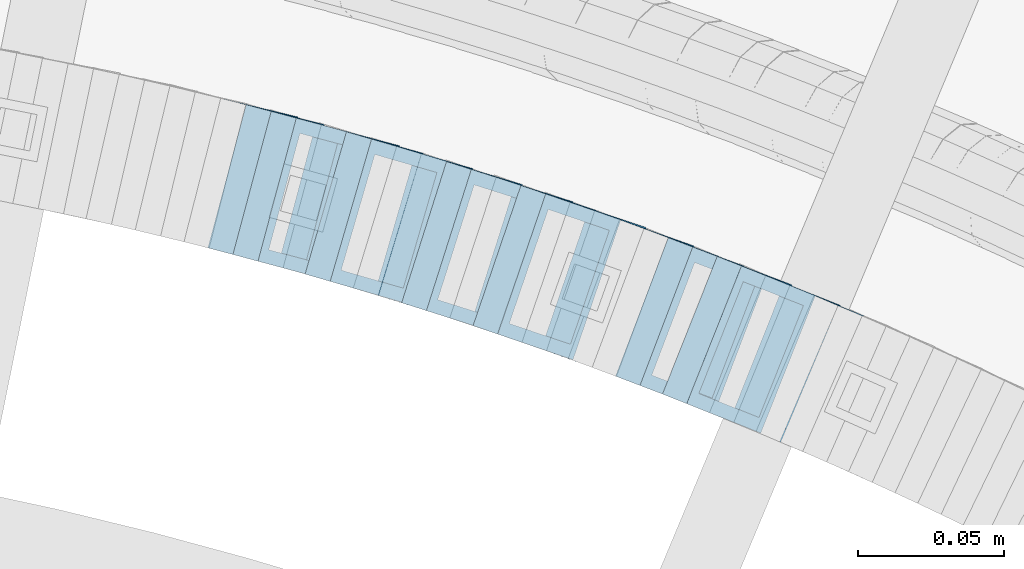
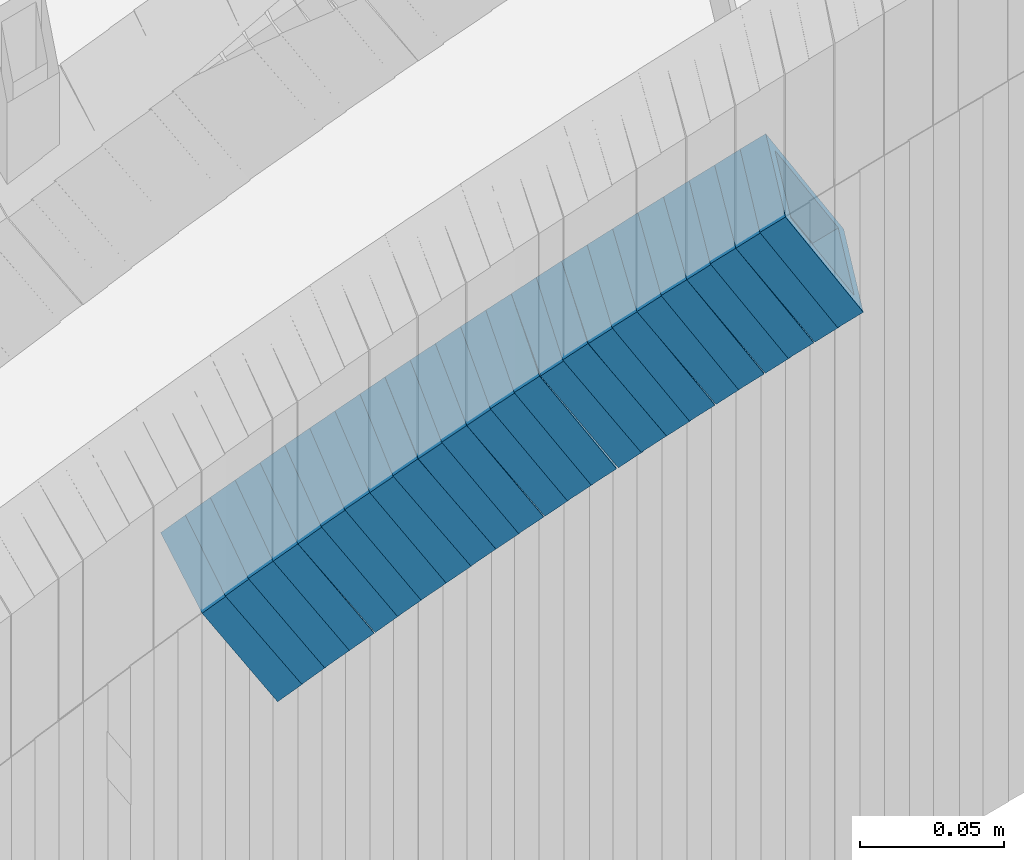
# One storey, part 753 of 975: 24 members.
"""IFC2X3 building model written with IfcOpenShell, lengths in millimetres."""

from ifc_helpers import new_model, si_unit, frame, origin_with_axes, place, context, subcontext, project, spatial, faceted_brep, material, type_object, element, save


model = new_model("IFC2X3")

# Units and contexts
model_context = context("Model", 3, precision=1e-05, world=origin_with_axes())
body_context = subcontext(model_context, "Body", "Model", "MODEL_VIEW")
ifc_project = project(units=[si_unit("LENGTHUNIT", "METRE", prefix="MILLI"), si_unit("AREAUNIT", "SQUARE_METRE"), si_unit("VOLUMEUNIT", "CUBIC_METRE"), si_unit("MASSUNIT", "GRAM", prefix="KILO"), si_unit("TIMEUNIT", "SECOND"), si_unit("PLANEANGLEUNIT", "RADIAN"), si_unit("SOLIDANGLEUNIT", "STERADIAN"), si_unit("THERMODYNAMICTEMPERATUREUNIT", "DEGREE_CELSIUS"), si_unit("LUMINOUSINTENSITYUNIT", "LUMEN")], contexts=[model_context])

# Site, building, storey
site_placement = place(None, origin_with_axes())
site = spatial("IfcSite", under=ifc_project, at=site_placement, CompositionType="ELEMENT")
building_placement = place(site_placement, origin_with_axes())
building = spatial("IfcBuilding", under=site, at=building_placement, Name="Undefined", CompositionType="ELEMENT")
storey_placement = place(building_placement, origin_with_axes())
storey = spatial("IfcBuildingStorey", under=building, at=storey_placement, Name="Undefined", CompositionType="ELEMENT", Elevation=0.0)

# Members
ifc_material = material()
member_type = type_object("IfcMemberType", Name="HSS2X2X.188_TUBES", PredefinedType="NOTDEFINED")
member_1_placement = place(storey_placement, frame((35253.2884853602, 4700.80640177664, 1383.78841235518), z_axis=(0.369459573118605, 0.929246804584777, -8.4115526988171e-11), x_axis=(0.783332654127522, -0.311445513050796, 0.537951341087703)))
element("IfcMember", 1, at=member_1_placement, inside=storey, type_object=member_type, material=ifc_material, Name="WALL", ObjectType="HSS2X2X.188_TUBES", context=body_context, shape_type="Brep", body=[
    faceted_brep([(0.0, 20.6374999999753, -20.6375000000298), (0.0, -20.6375000000153, -20.6375000000153), (10.6004716875832, -20.6375000000153, -20.6375000000553), (10.6004716875814, 20.6374999999898, -20.6375000000444), (0.0, -20.6374999999825, 20.6375000000335), (10.6004716876068, -20.6375000000044, 20.6374999999862), (0.0, 20.6375000000116, 20.6375000000189), (10.6004716876032, 20.6374999999989, 20.6374999999971), (0.0, 25.3999999999724, -25.4000000000342), (0.0, 25.400000000016, 25.4000000000196), (10.600471687605, 25.4000000000015, 25.4000000000051), (10.6004716875814, 25.3999999999869, -25.4000000000487), (0.0, -25.399999999976, 25.4000000000378), (10.6004716876068, -25.4000000000015, 25.3999999999905), (0.0, -25.400000000016, -25.4000000000196), (10.6004716875814, -25.4000000000178, -25.4000000000669)], [[[0, 1, 2, 3]], [[1, 4, 5, 2]], [[4, 6, 7, 5]], [[6, 0, 3, 7]], [[8, 9, 10, 11]], [[9, 12, 13, 10]], [[12, 14, 15, 13]], [[14, 8, 11, 15]], [[13, 15, 11, 10], [5, 7, 3, 2]], [[14, 12, 9, 8], [6, 4, 1, 0]]]),
])
member_2_placement = place(storey_placement, frame((35269.5539152076, 4694.18900324378, 1395.26256360758), z_axis=(0.379066925316801, 0.925369259339679, -5.31522346136625e-11), x_axis=(0.781005694706522, -0.319930043879788, 0.536353308798463)))
element("IfcMember", 2, at=member_2_placement, inside=storey, type_object=member_type, material=ifc_material, Name="WALL", ObjectType="HSS2X2X.188_TUBES", context=body_context, shape_type="Brep", body=[
    faceted_brep([(0.0, 20.6374999999753, -20.6375000000298), (0.0, -20.6375000000153, -20.6375000000153), (10.6348483769107, -20.637499999988, -20.6374999999825), (10.6348483768415, 20.6374999999734, -20.6375000001026), (0.0, -20.6374999999825, 20.6375000000335), (10.6348483769852, -20.6374999999589, 20.6375000001462), (0.0, 20.6375000000116, 20.6375000000189), (10.6348483769161, 20.6375000000044, 20.6375000000226), (0.0, 25.3999999999724, -25.4000000000342), (0.0, 25.400000000016, 25.4000000000196), (10.6348483769179, 25.4000000000015, 25.4000000000233), (10.6348483768288, 25.3999999999669, -25.4000000001324), (0.0, -25.399999999976, 25.4000000000378), (10.6348483769998, -25.3999999999505, 25.4000000001688), (0.0, -25.400000000016, -25.4000000000196), (10.6348483769107, -25.3999999999887, -25.3999999999833)], [[[0, 1, 2, 3]], [[1, 4, 5, 2]], [[4, 6, 7, 5]], [[6, 0, 3, 7]], [[8, 9, 10, 11]], [[9, 12, 13, 10]], [[12, 14, 15, 13]], [[14, 8, 11, 15]], [[13, 15, 11, 10], [5, 7, 3, 2]], [[14, 12, 9, 8], [6, 4, 1, 0]]]),
])
member_3_placement = place(storey_placement, frame((35261.7455766165, 4697.44394380727, 1389.59723822413), z_axis=(0.369459573118605, 0.929246804584777, -8.4115526988171e-11), x_axis=(0.779351312004385, -0.309862570001833, 0.544606941003237)))
element("IfcMember", 3, at=member_3_placement, inside=storey, type_object=member_type, material=ifc_material, Name="WALL", ObjectType="HSS2X2X.188_TUBES", context=body_context, shape_type="Brep", body=[
    faceted_brep([(0.0, 20.6374999999753, -20.6375000000298), (0.0, -20.6375000000153, -20.6375000000153), (10.648004507897, -20.6374999999862, -20.637499999968), (10.6480045078188, 20.6374999999771, -20.6375000000808), (0.0, -20.6374999999825, 20.6375000000335), (10.6480045079406, -20.6374999999698, 20.6375000001062), (0.0, 20.6375000000116, 20.6375000000189), (10.6480045078679, 20.6374999999935, 20.6375000000007), (0.0, 25.3999999999724, -25.4000000000342), (0.0, 25.400000000016, 25.4000000000196), (10.6480045078661, 25.3999999999905, 25.4000000000015), (10.648004507806, 25.3999999999705, -25.4000000000997), (0.0, -25.399999999976, 25.4000000000378), (10.6480045079552, -25.3999999999633, 25.4000000001288), (0.0, -25.400000000016, -25.4000000000196), (10.6480045078988, -25.3999999999814, -25.3999999999651)], [[[0, 1, 2, 3]], [[1, 4, 5, 2]], [[4, 6, 7, 5]], [[6, 0, 3, 7]], [[8, 9, 10, 11]], [[9, 12, 13, 10]], [[12, 14, 15, 13]], [[14, 8, 11, 15]], [[13, 15, 11, 10], [5, 7, 3, 2]], [[14, 12, 9, 8], [6, 4, 1, 0]]]),
])
member_4_placement = place(storey_placement, frame((35236.8444774971, 4707.27920437991, 1372.24919434095), z_axis=(0.355995327441539, 0.934487734986282, -3.27830093738158e-10), x_axis=(0.789193496498296, -0.300645141189797, 0.535524158338129)))
element("IfcMember", 4, at=member_4_placement, inside=storey, type_object=member_type, material=ifc_material, Name="WALL", ObjectType="HSS2X2X.188_TUBES", context=body_context, shape_type="Brep", body=[
    faceted_brep([(0.0, 20.6374999999753, -20.6375000000298), (0.0, -20.6375000000153, -20.6375000000153), (10.6395488625676, -20.6374999999771, -20.6374999999716), (10.6395488625531, 20.6374999999916, -20.6375000000189), (0.0, -20.6374999999825, 20.6375000000335), (10.6395488625731, -20.6374999999844, 20.6375000000153), (0.0, 20.6375000000116, 20.6375000000189), (10.6395488625585, 20.6374999999825, 20.637499999968), (0.0, 25.3999999999724, -25.4000000000342), (0.0, 25.400000000016, 25.4000000000196), (10.6395488625567, 25.3999999999778, 25.3999999999614), (10.6395488625494, 25.3999999999887, -25.4000000000233), (0.0, -25.399999999976, 25.4000000000378), (10.6395488625749, -25.3999999999851, 25.400000000016), (0.0, -25.400000000016, -25.4000000000196), (10.6395488625658, -25.399999999976, -25.3999999999687)], [[[0, 1, 2, 3]], [[1, 4, 5, 2]], [[4, 6, 7, 5]], [[6, 0, 3, 7]], [[8, 9, 10, 11]], [[9, 12, 13, 10]], [[12, 14, 15, 13]], [[14, 8, 11, 15]], [[13, 15, 11, 10], [5, 7, 3, 2]], [[14, 12, 9, 8], [6, 4, 1, 0]]]),
])
member_5_placement = place(storey_placement, frame((35245.4023293793, 4704.01907032952, 1378.05724534033), z_axis=(0.355995327441539, 0.934487734986282, -3.27830093738158e-10), x_axis=(0.785218207651468, -0.299130745867334, 0.542174476759528)))
element("IfcMember", 5, at=member_5_placement, inside=storey, type_object=member_type, material=ifc_material, Name="WALL", ObjectType="HSS2X2X.188_TUBES", context=body_context, shape_type="Brep", body=[
    faceted_brep([(0.0, 20.6374999999753, -20.6375000000298), (0.0, -20.6375000000153, -20.6375000000153), (10.6985980389491, -20.6375000000317, -20.6375000000698), (10.6985980389982, 20.6375000000116, -20.6374999999643), (0.0, -20.6374999999825, 20.6375000000335), (10.6985980389818, -20.6374999999989, 20.6374999999789), (0.0, 20.6375000000116, 20.6375000000189), (10.6985980390309, 20.6375000000407, 20.6375000000808), (0.0, 25.3999999999724, -25.4000000000342), (0.0, 25.400000000016, 25.4000000000196), (10.6985980390382, 25.4000000000487, 25.4000000000997), (10.6985980390036, 25.4000000000142, -25.3999999999542), (0.0, -25.399999999976, 25.4000000000378), (10.6985980389763, -25.4000000000033, 25.3999999999724), (0.0, -25.400000000016, -25.4000000000196), (10.6985980389418, -25.400000000036, -25.4000000000851)], [[[0, 1, 2, 3]], [[1, 4, 5, 2]], [[4, 6, 7, 5]], [[6, 0, 3, 7]], [[8, 9, 10, 11]], [[9, 12, 13, 10]], [[12, 14, 15, 13]], [[14, 8, 11, 15]], [[13, 15, 11, 10], [5, 7, 3, 2]], [[14, 12, 9, 8], [6, 4, 1, 0]]]),
])
member_6_placement = place(storey_placement, frame((35229.0208619484, 4710.29550494927, 1366.64856462284), z_axis=(0.34988624138305, 0.936792195788822, -3.29973545376561e-10), x_axis=(0.783786568187665, -0.29273956106995, 0.547706276130898)))
element("IfcMember", 6, at=member_6_placement, inside=storey, type_object=member_type, material=ifc_material, Name="WALL", ObjectType="HSS2X2X.188_TUBES", context=body_context, shape_type="Brep", body=[
    faceted_brep([(0.0, 20.6374999999753, -20.6375000000298), (0.0, -20.6375000000153, -20.6375000000153), (10.5948100501191, -20.6375000000335, -20.6375000000844), (10.5948100501555, 20.6374999999971, -20.6375000000116), (0.0, -20.6374999999825, 20.6375000000335), (10.5948100501446, -20.6375000000098, 20.6374999999571), (0.0, 20.6375000000116, 20.6375000000189), (10.5948100501828, 20.6375000000189, 20.6375000000298), (0.0, 25.3999999999724, -25.4000000000342), (0.0, 25.400000000016, 25.4000000000196), (10.5948100501919, 25.4000000000251, 25.4000000000451), (10.5948100501591, 25.3999999999978, -25.4000000000051), (0.0, -25.399999999976, 25.4000000000378), (10.5948100501482, -25.4000000000106, 25.3999999999578), (0.0, -25.400000000016, -25.4000000000196), (10.5948100501118, -25.4000000000378, -25.400000000096)], [[[0, 1, 2, 3]], [[1, 4, 5, 2]], [[4, 6, 7, 5]], [[6, 0, 3, 7]], [[8, 9, 10, 11]], [[9, 12, 13, 10]], [[12, 14, 15, 13]], [[14, 8, 11, 15]], [[13, 15, 11, 10], [5, 7, 3, 2]], [[14, 12, 9, 8], [6, 4, 1, 0]]]),
])
member_7_placement = place(storey_placement, frame((35220.4781748153, 4713.50590332083, 1360.77332488473), z_axis=(0.346222870079248, 0.938152292665795, -6.04968590778299e-11), x_axis=(0.791397023826088, -0.29206318693586, 0.5370194088821)))
element("IfcMember", 7, at=member_7_placement, inside=storey, type_object=member_type, material=ifc_material, Name="WALL", ObjectType="HSS2X2X.188_TUBES", context=body_context, shape_type="Brep", body=[
    faceted_brep([(0.0, 20.6374999999753, -20.6375000000298), (0.0, -20.6375000000153, -20.6375000000153), (10.6061303028146, -20.6374999999571, -20.6374999999643), (10.6061303027491, 20.6374999999971, -20.6375000000007), (0.0, -20.6374999999825, 20.6375000000335), (10.6061303027855, -20.6374999999825, 20.6375000000116), (0.0, 20.6375000000116, 20.6375000000189), (10.6061303027236, 20.637499999968, 20.6374999999716), (0.0, 25.3999999999724, -25.4000000000342), (0.0, 25.400000000016, 25.4000000000196), (10.6061303027163, 25.3999999999651, 25.3999999999651), (10.6061303027454, 25.3999999999942, -25.4000000000051), (0.0, -25.399999999976, 25.4000000000378), (10.6061303027891, -25.3999999999796, 25.4000000000124), (0.0, -25.400000000016, -25.4000000000196), (10.6061303028182, -25.3999999999505, -25.3999999999542)], [[[0, 1, 2, 3]], [[1, 4, 5, 2]], [[4, 6, 7, 5]], [[6, 0, 3, 7]], [[8, 9, 10, 11]], [[9, 12, 13, 10]], [[12, 14, 15, 13]], [[14, 8, 11, 15]], [[13, 15, 11, 10], [5, 7, 3, 2]], [[14, 12, 9, 8], [6, 4, 1, 0]]]),
])
member_8_placement = place(storey_placement, frame((35204.0724030319, 4719.48024269207, 1349.40596860365), z_axis=(0.336336396745049, 0.941741911685233, 4.28894963988568e-11), x_axis=(0.789507159090244, -0.281966843032229, 0.545135896062339)))
element("IfcMember", 8, at=member_8_placement, inside=storey, type_object=member_type, material=ifc_material, Name="WALL", ObjectType="HSS2X2X.188_TUBES", context=body_context, shape_type="Brep", body=[
    faceted_brep([(0.0, 20.6374999999753, -20.6375000000298), (0.0, -20.6375000000153, -20.6375000000153), (10.6395488625676, -20.6374999999771, -20.6374999999716), (10.6395488625531, 20.6374999999916, -20.6375000000189), (0.0, -20.6374999999825, 20.6375000000335), (10.6395488625731, -20.6374999999844, 20.6375000000153), (0.0, 20.6375000000116, 20.6375000000189), (10.6395488625585, 20.6374999999825, 20.637499999968), (0.0, 25.3999999999724, -25.4000000000342), (0.0, 25.400000000016, 25.4000000000196), (10.6395488625567, 25.3999999999778, 25.3999999999614), (10.6395488625494, 25.3999999999887, -25.4000000000233), (0.0, -25.399999999976, 25.4000000000378), (10.6395488625749, -25.3999999999851, 25.400000000016), (0.0, -25.400000000016, -25.4000000000196), (10.6395488625658, -25.399999999976, -25.3999999999687)], [[[0, 1, 2, 3]], [[1, 4, 5, 2]], [[4, 6, 7, 5]], [[6, 0, 3, 7]], [[8, 9, 10, 11]], [[9, 12, 13, 10]], [[12, 14, 15, 13]], [[14, 8, 11, 15]], [[13, 15, 11, 10], [5, 7, 3, 2]], [[14, 12, 9, 8], [6, 4, 1, 0]]]),
])
member_9_placement = place(storey_placement, frame((35212.3233836713, 4716.58743925957, 1355.03213828432), z_axis=(0.332820118030351, 0.942990333478696, 1.27812427308527e-10), x_axis=(0.797007326545216, -0.281296703839583, 0.534463736695234)))
element("IfcMember", 9, at=member_9_placement, inside=storey, type_object=member_type, material=ifc_material, Name="WALL", ObjectType="HSS2X2X.188_TUBES", context=body_context, shape_type="Brep", body=[
    faceted_brep([(0.0, 20.6374999999753, -20.6375000000298), (0.0, -20.6375000000153, -20.6375000000153), (10.6625512894789, -20.6374999999625, -20.6374999999389), (10.6625512893879, 20.6374999999789, -20.6375000000371), (0.0, -20.6374999999825, 20.6375000000335), (10.6625512894352, -20.6374999999989, 20.6375000000153), (0.0, 20.6375000000116, 20.6375000000189), (10.6625512893443, 20.6374999999443, 20.6374999999134), (0.0, 25.3999999999724, -25.4000000000342), (0.0, 25.400000000016, 25.4000000000196), (10.6625512893297, 25.3999999999342, 25.3999999998996), (10.6625512893916, 25.399999999976, -25.4000000000415), (0.0, -25.399999999976, 25.4000000000378), (10.6625512894389, -25.399999999996, 25.400000000016), (0.0, -25.400000000016, -25.4000000000196), (10.6625512894971, -25.3999999999523, -25.3999999999214)], [[[0, 1, 2, 3]], [[1, 4, 5, 2]], [[4, 6, 7, 5]], [[6, 0, 3, 7]], [[8, 9, 10, 11]], [[9, 12, 13, 10]], [[12, 14, 15, 13]], [[14, 8, 11, 15]], [[13, 15, 11, 10], [5, 7, 3, 2]], [[14, 12, 9, 8], [6, 4, 1, 0]]]),
])
member_10_placement = place(storey_placement, frame((35196.1865627476, 4722.41326902608, 1343.64273896002), z_axis=(0.316227766269039, 0.948683297966447, 1.71134388438077e-10), x_axis=(0.797688065098583, -0.265896022032794, 0.541288330066718)))
element("IfcMember", 10, at=member_10_placement, inside=storey, type_object=member_type, material=ifc_material, Name="WALL", ObjectType="HSS2X2X.188_TUBES", context=body_context, shape_type="Brep", body=[
    faceted_brep([(0.0, 20.6374999999753, -20.6375000000298), (0.0, -20.6375000000153, -20.6375000000153), (10.5290075505945, -20.637499999968, -20.6375000000116), (10.5290075505436, 20.6374999999898, -20.637499999998), (0.0, -20.6374999999825, 20.6375000000335), (10.5290075505145, -20.6375000000189, 20.637500000008), (0.0, 20.6375000000116, 20.6375000000189), (10.5290075504672, 20.6374999999462, 20.6375000000198), (0.0, 25.3999999999724, -25.4000000000342), (0.0, 25.400000000016, 25.4000000000196), (10.5290075504563, 25.399999999936, 25.4000000000224), (10.5290075505472, 25.3999999999869, -25.3999999999987), (0.0, -25.399999999976, 25.4000000000378), (10.5290075505072, -25.4000000000196, 25.4000000000106), (0.0, -25.400000000016, -25.4000000000196), (10.5290075506091, -25.3999999999651, -25.4000000000151)], [[[0, 1, 2, 3]], [[1, 4, 5, 2]], [[4, 6, 7, 5]], [[6, 0, 3, 7]], [[8, 9, 10, 11]], [[9, 12, 13, 10]], [[12, 14, 15, 13]], [[14, 8, 11, 15]], [[13, 15, 11, 10], [5, 7, 3, 2]], [[14, 12, 9, 8], [6, 4, 1, 0]]]),
])
member_11_placement = place(storey_placement, frame((35187.355526214, 4725.32324595788, 1337.85453112297), z_axis=(0.322900627824754, 0.946432873768858, -5.78972958464874e-11), x_axis=(0.799082549180594, -0.27262816406165, 0.535855357121134)))
element("IfcMember", 11, at=member_11_placement, inside=storey, type_object=member_type, material=ifc_material, Name="WALL", ObjectType="HSS2X2X.188_TUBES", context=body_context, shape_type="Brep", body=[
    faceted_brep([(0.0, 20.6374999999753, -20.6375000000298), (0.0, -20.6375000000153, -20.6375000000153), (10.6395488625676, -20.6374999999771, -20.6374999999716), (10.6395488625531, 20.6374999999916, -20.6375000000189), (0.0, -20.6374999999825, 20.6375000000335), (10.6395488625731, -20.6374999999844, 20.6375000000153), (0.0, 20.6375000000116, 20.6375000000189), (10.6395488625585, 20.6374999999825, 20.637499999968), (0.0, 25.3999999999724, -25.4000000000342), (0.0, 25.400000000016, 25.4000000000196), (10.6395488625567, 25.3999999999778, 25.3999999999614), (10.6395488625494, 25.3999999999887, -25.4000000000233), (0.0, -25.399999999976, 25.4000000000378), (10.6395488625749, -25.3999999999851, 25.400000000016), (0.0, -25.400000000016, -25.4000000000196), (10.6395488625658, -25.399999999976, -25.3999999999687)], [[[0, 1, 2, 3]], [[1, 4, 5, 2]], [[4, 6, 7, 5]], [[6, 0, 3, 7]], [[8, 9, 10, 11]], [[9, 12, 13, 10]], [[12, 14, 15, 13]], [[14, 8, 11, 15]], [[13, 15, 11, 10], [5, 7, 3, 2]], [[14, 12, 9, 8], [6, 4, 1, 0]]]),
])
member_12_placement = place(storey_placement, frame((35179.188656162, 4728.16356221956, 1332.17641036394), z_axis=(0.3128735752059, 0.949794780959486, 1.3263093023852e-10), x_axis=(0.801102899019735, -0.263892720006487, 0.537210180013143)))
element("IfcMember", 12, at=member_12_placement, inside=storey, type_object=member_type, material=ifc_material, Name="WALL", ObjectType="HSS2X2X.188_TUBES", context=body_context, shape_type="Brep", body=[
    faceted_brep([(0.0, 20.6374999999753, -20.6375000000298), (0.0, -20.6375000000153, -20.6375000000153), (10.6061303028146, -20.6374999999571, -20.6374999999643), (10.6061303027491, 20.6374999999971, -20.6375000000007), (0.0, -20.6374999999825, 20.6375000000335), (10.6061303027855, -20.6374999999825, 20.6375000000116), (0.0, 20.6375000000116, 20.6375000000189), (10.6061303027236, 20.637499999968, 20.6374999999716), (0.0, 25.3999999999724, -25.4000000000342), (0.0, 25.400000000016, 25.4000000000196), (10.6061303027163, 25.3999999999651, 25.3999999999651), (10.6061303027454, 25.3999999999942, -25.4000000000051), (0.0, -25.399999999976, 25.4000000000378), (10.6061303027891, -25.3999999999796, 25.4000000000124), (0.0, -25.400000000016, -25.4000000000196), (10.6061303028182, -25.3999999999505, -25.3999999999542)], [[[0, 1, 2, 3]], [[1, 4, 5, 2]], [[4, 6, 7, 5]], [[6, 0, 3, 7]], [[8, 9, 10, 11]], [[9, 12, 13, 10]], [[12, 14, 15, 13]], [[14, 8, 11, 15]], [[13, 15, 11, 10], [5, 7, 3, 2]], [[14, 12, 9, 8], [6, 4, 1, 0]]]),
])
member_13_placement = place(storey_placement, frame((35171.1837911755, 4730.85724423868, 1326.50676413537), z_axis=(0.302740811621275, 0.953072925320456, -2.97833366857958e-10), x_axis=(0.798976638234463, -0.253792579074509, 0.545184059160083)))
element("IfcMember", 13, at=member_13_placement, inside=storey, type_object=member_type, material=ifc_material, Name="WALL", ObjectType="HSS2X2X.188_TUBES", context=body_context, shape_type="Brep", body=[
    faceted_brep([(0.0, 20.6374999999753, -20.6375000000298), (0.0, -20.6375000000153, -20.6375000000153), (10.6395488625676, -20.6374999999771, -20.6374999999716), (10.6395488625531, 20.6374999999916, -20.6375000000189), (0.0, -20.6374999999825, 20.6375000000335), (10.6395488625731, -20.6374999999844, 20.6375000000153), (0.0, 20.6375000000116, 20.6375000000189), (10.6395488625585, 20.6374999999825, 20.637499999968), (0.0, 25.3999999999724, -25.4000000000342), (0.0, 25.400000000016, 25.4000000000196), (10.6395488625567, 25.3999999999778, 25.3999999999614), (10.6395488625494, 25.3999999999887, -25.4000000000233), (0.0, -25.399999999976, 25.4000000000378), (10.6395488625749, -25.3999999999851, 25.400000000016), (0.0, -25.400000000016, -25.4000000000196), (10.6395488625658, -25.399999999976, -25.3999999999687)], [[[0, 1, 2, 3]], [[1, 4, 5, 2]], [[4, 6, 7, 5]], [[6, 0, 3, 7]], [[8, 9, 10, 11]], [[9, 12, 13, 10]], [[12, 14, 15, 13]], [[14, 8, 11, 15]], [[13, 15, 11, 10], [5, 7, 3, 2]], [[14, 12, 9, 8], [6, 4, 1, 0]]]),
])
member_14_placement = place(storey_placement, frame((35162.5226429071, 4733.60843251215, 1320.69775449172), z_axis=(0.302740811621275, 0.953072925320456, -2.97833366857958e-10), x_axis=(0.80306695879002, -0.255091856933247, 0.538527254859117)))
element("IfcMember", 14, at=member_14_placement, inside=storey, type_object=member_type, material=ifc_material, Name="WALL", ObjectType="HSS2X2X.188_TUBES", context=body_context, shape_type="Brep", body=[
    faceted_brep([(0.0, 20.6374999999753, -20.6375000000298), (0.0, -20.6375000000153, -20.6375000000153), (10.5806427026419, -20.6374999999607, -20.6374999999316), (10.5806427026473, 20.6375000000444, -20.6374999999207), (0.0, -20.6374999999825, 20.6375000000335), (10.5806427025509, -20.6375000000207, 20.6374999999643), (0.0, 20.6375000000116, 20.6375000000189), (10.5806427025545, 20.6374999999862, 20.6374999999716), (0.0, 25.3999999999724, -25.4000000000342), (0.0, 25.400000000016, 25.4000000000196), (10.5806427025436, 25.3999999999796, 25.3999999999614), (10.5806427026582, 25.4000000000542, -25.3999999999105), (0.0, -25.399999999976, 25.4000000000378), (10.5806427025418, -25.4000000000287, 25.3999999999542), (0.0, -25.400000000016, -25.4000000000196), (10.5806427026528, -25.3999999999542, -25.3999999999178)], [[[0, 1, 2, 3]], [[1, 4, 5, 2]], [[4, 6, 7, 5]], [[6, 0, 3, 7]], [[8, 9, 10, 11]], [[9, 12, 13, 10]], [[12, 14, 15, 13]], [[14, 8, 11, 15]], [[13, 15, 11, 10], [5, 7, 3, 2]], [[14, 12, 9, 8], [6, 4, 1, 0]]]),
])
member_15_placement = place(storey_placement, frame((35154.2499598661, 4736.30662535833, 1314.95224215174), z_axis=(0.289389501515252, 0.957211427226375, 2.71342742053093e-10), x_axis=(0.808269248899506, -0.244360470969574, 0.535713338933199)))
element("IfcMember", 15, at=member_15_placement, inside=storey, type_object=member_type, material=ifc_material, Name="WALL", ObjectType="HSS2X2X.188_TUBES", context=body_context, shape_type="Brep", body=[
    faceted_brep([(0.0, 20.6374999999753, -20.6375000000298), (0.0, -20.6375000000153, -20.6375000000153), (10.6395488625676, -20.6374999999771, -20.6374999999716), (10.6395488625531, 20.6374999999916, -20.6375000000189), (0.0, -20.6374999999825, 20.6375000000335), (10.6395488625731, -20.6374999999844, 20.6375000000153), (0.0, 20.6375000000116, 20.6375000000189), (10.6395488625585, 20.6374999999825, 20.637499999968), (0.0, 25.3999999999724, -25.4000000000342), (0.0, 25.400000000016, 25.4000000000196), (10.6395488625567, 25.3999999999778, 25.3999999999614), (10.6395488625494, 25.3999999999887, -25.4000000000233), (0.0, -25.399999999976, 25.4000000000378), (10.6395488625749, -25.3999999999851, 25.400000000016), (0.0, -25.400000000016, -25.4000000000196), (10.6395488625658, -25.399999999976, -25.3999999999687)], [[[0, 1, 2, 3]], [[1, 4, 5, 2]], [[4, 6, 7, 5]], [[6, 0, 3, 7]], [[8, 9, 10, 11]], [[9, 12, 13, 10]], [[12, 14, 15, 13]], [[14, 8, 11, 15]], [[13, 15, 11, 10], [5, 7, 3, 2]], [[14, 12, 9, 8], [6, 4, 1, 0]]]),
])
member_16_placement = place(storey_placement, frame((35145.9191034289, 4738.80842000043, 1309.32795960028), z_axis=(0.292504341929562, 0.956264194640976, 2.45725004788255e-11), x_axis=(0.800853960868544, -0.244967093959754, 0.546465054910263)))
element("IfcMember", 16, at=member_16_placement, inside=storey, type_object=member_type, material=ifc_material, Name="WALL", ObjectType="HSS2X2X.188_TUBES", context=body_context, shape_type="Brep", body=[
    faceted_brep([(0.0, 20.6374999999753, -20.6375000000298), (0.0, -20.6375000000153, -20.6375000000153), (10.6061303028146, -20.6374999999571, -20.6374999999643), (10.6061303027491, 20.6374999999971, -20.6375000000007), (0.0, -20.6374999999825, 20.6375000000335), (10.6061303027855, -20.6374999999825, 20.6375000000116), (0.0, 20.6375000000116, 20.6375000000189), (10.6061303027236, 20.637499999968, 20.6374999999716), (0.0, 25.3999999999724, -25.4000000000342), (0.0, 25.400000000016, 25.4000000000196), (10.6061303027163, 25.3999999999651, 25.3999999999651), (10.6061303027454, 25.3999999999942, -25.4000000000051), (0.0, -25.399999999976, 25.4000000000378), (10.6061303027891, -25.3999999999796, 25.4000000000124), (0.0, -25.400000000016, -25.4000000000196), (10.6061303028182, -25.3999999999505, -25.3999999999542)], [[[0, 1, 2, 3]], [[1, 4, 5, 2]], [[4, 6, 7, 5]], [[6, 0, 3, 7]], [[8, 9, 10, 11]], [[9, 12, 13, 10]], [[12, 14, 15, 13]], [[14, 8, 11, 15]], [[13, 15, 11, 10], [5, 7, 3, 2]], [[14, 12, 9, 8], [6, 4, 1, 0]]]),
])
for number, where, z_axis, x_axis, name in (
    (17, (35137.4811105688, 4741.46030198171, 1303.47178395406), (0.279142362805979, 0.960249728605583, -4.85008513351205e-11), (0.810096010051265, -0.235493026014955, 0.536924100034019), "WALL"),
    (18, (35128.8811105688, 4743.9603019817, 1297.77178395406), (0.279142362805979, 0.960249728605583, -4.85008513351205e-11), (0.810096010051265, -0.235493026014955, 0.536924100034019), "WALL"),
    (19, (35112.5078691576, 4748.73762569707, 1286.41833438161), (0.258361739614942, 0.966048244914891, -2.28028739002184e-10), (0.809414005296637, -0.216471187079362, 0.545883864200167), "WALL"),
):
    element("IfcMember", number, at=place(storey_placement, frame(where, z_axis=z_axis, x_axis=x_axis)), inside=storey, type_object=member_type, material=ifc_material, Name=name, ObjectType="HSS2X2X.188_TUBES", context=body_context, shape_type="Brep", body=[
        faceted_brep([(0.0, 20.6374999999753, -20.6375000000298), (0.0, -20.6375000000153, -20.6375000000153), (10.6216759506497, -20.637499999968, -20.6374999999534), (10.6216759506497, 20.6375000000262, -20.6374999999643), (0.0, -20.6374999999825, 20.6375000000335), (10.6216759506169, -20.6374999999935, 20.637500000008), (0.0, 20.6375000000116, 20.6375000000189), (10.6216759506242, 20.6375000000007, 20.6374999999971), (0.0, 25.3999999999724, -25.4000000000342), (0.0, 25.400000000016, 25.4000000000196), (10.6216759506169, 25.3999999999978, 25.3999999999869), (10.6216759506533, 25.4000000000269, -25.3999999999614), (0.0, -25.399999999976, 25.4000000000378), (10.6216759506242, -25.3999999999942, 25.4000000000051), (0.0, -25.400000000016, -25.4000000000196), (10.6216759506569, -25.3999999999614, -25.3999999999432)], [[[0, 1, 2, 3]], [[1, 4, 5, 2]], [[4, 6, 7, 5]], [[6, 0, 3, 7]], [[8, 9, 10, 11]], [[9, 12, 13, 10]], [[12, 14, 15, 13]], [[14, 8, 11, 15]], [[13, 15, 11, 10], [5, 7, 3, 2]], [[14, 12, 9, 8], [6, 4, 1, 0]]]),
    ])
member_17_placement = place(storey_placement, frame((35120.6126676541, 4746.41852562221, 1292.09074376093), z_axis=(0.26879896765246, 0.96319630137837, -2.78632569461479e-10), x_axis=(0.811862852084026, -0.226566377023402, 0.538095146055492)))
element("IfcMember", 20, at=member_17_placement, inside=storey, type_object=member_type, material=ifc_material, Name="WALL", ObjectType="HSS2X2X.188_TUBES", context=body_context, shape_type="Brep", body=[
    faceted_brep([(0.0, 20.6374999999753, -20.6375000000298), (0.0, -20.6375000000153, -20.6375000000153), (10.5948100501191, -20.6375000000335, -20.6375000000844), (10.5948100501555, 20.6374999999971, -20.6375000000116), (0.0, -20.6374999999825, 20.6375000000335), (10.5948100501446, -20.6375000000098, 20.6374999999571), (0.0, 20.6375000000116, 20.6375000000189), (10.5948100501828, 20.6375000000189, 20.6375000000298), (0.0, 25.3999999999724, -25.4000000000342), (0.0, 25.400000000016, 25.4000000000196), (10.5948100501919, 25.4000000000251, 25.4000000000451), (10.5948100501591, 25.3999999999978, -25.4000000000051), (0.0, -25.399999999976, 25.4000000000378), (10.5948100501482, -25.4000000000106, 25.3999999999578), (0.0, -25.400000000016, -25.4000000000196), (10.5948100501118, -25.4000000000378, -25.400000000096)], [[[0, 1, 2, 3]], [[1, 4, 5, 2]], [[4, 6, 7, 5]], [[6, 0, 3, 7]], [[8, 9, 10, 11]], [[9, 12, 13, 10]], [[12, 14, 15, 13]], [[14, 8, 11, 15]], [[13, 15, 11, 10], [5, 7, 3, 2]], [[14, 12, 9, 8], [6, 4, 1, 0]]]),
])
member_18_placement = place(storey_placement, frame((35103.7444917718, 4751.08131964906, 1280.60910193306), z_axis=(0.258361739614942, 0.966048244914891, -2.28028739002184e-10), x_axis=(0.813568485883084, -0.217582269968782, 0.539225624922572)))
element("IfcMember", 21, at=member_18_placement, inside=storey, type_object=member_type, material=ifc_material, Name="WALL", ObjectType="HSS2X2X.188_TUBES", context=body_context, shape_type="Brep", body=[
    faceted_brep([(0.0, 20.6374999999753, -20.6375000000298), (0.0, -20.6375000000153, -20.6375000000153), (10.5744976239494, -20.6375000000207, -20.6375000000335), (10.5744976239657, 20.6375000000098, -20.637500000008), (0.0, -20.6374999999825, 20.6375000000335), (10.5744976239639, -20.6375000000244, 20.6374999999753), (0.0, 20.6375000000116, 20.6375000000189), (10.5744976239803, 20.6374999999989, 20.6374999999935), (0.0, 25.3999999999724, -25.4000000000342), (0.0, 25.400000000016, 25.4000000000196), (10.5744976239857, 25.4000000000051, 25.4000000000015), (10.5744976239675, 25.4000000000124, -25.4000000000051), (0.0, -25.399999999976, 25.4000000000378), (10.5744976239639, -25.4000000000287, 25.3999999999724), (0.0, -25.400000000016, -25.4000000000196), (10.5744976239494, -25.4000000000215, -25.4000000000378)], [[[0, 1, 2, 3]], [[1, 4, 5, 2]], [[4, 6, 7, 5]], [[6, 0, 3, 7]], [[8, 9, 10, 11]], [[9, 12, 13, 10]], [[12, 14, 15, 13]], [[14, 8, 11, 15]], [[13, 15, 11, 10], [5, 7, 3, 2]], [[14, 12, 9, 8], [6, 4, 1, 0]]]),
])
member_19_placement = place(storey_placement, frame((35086.9153413096, 4755.65257317993, 1269.16775488254), z_axis=(0.245156736150871, 0.969483457682416, 1.44857494888129e-10), x_axis=(0.814222786177756, -0.205895417044883, 0.542815191118346)))
element("IfcMember", 22, at=member_19_placement, inside=storey, type_object=member_type, material=ifc_material, Name="WALL", ObjectType="HSS2X2X.188_TUBES", context=body_context, shape_type="Brep", body=[
    faceted_brep([(0.0, 20.6374999999753, -20.6375000000298), (0.0, -20.6375000000153, -20.6375000000153), (10.6906501205649, -20.6374999999844, -20.637499999968), (10.690650120574, 20.6375000000098, -20.6374999999716), (0.0, -20.6374999999825, 20.6375000000335), (10.6906501205467, -20.6374999999844, 20.637500000008), (0.0, 20.6375000000116, 20.6375000000189), (10.6906501205558, 20.637500000008, 20.6375000000007), (0.0, 25.3999999999724, -25.4000000000342), (0.0, 25.400000000016, 25.4000000000196), (10.6906501205522, 25.4000000000087, 25.3999999999978), (10.6906501205813, 25.4000000000124, -25.3999999999651), (0.0, -25.399999999976, 25.4000000000378), (10.6906501205431, -25.3999999999833, 25.4000000000051), (0.0, -25.400000000016, -25.4000000000196), (10.6906501205704, -25.3999999999833, -25.3999999999614)], [[[0, 1, 2, 3]], [[1, 4, 5, 2]], [[4, 6, 7, 5]], [[6, 0, 3, 7]], [[8, 9, 10, 11]], [[9, 12, 13, 10]], [[12, 14, 15, 13]], [[14, 8, 11, 15]], [[13, 15, 11, 10], [5, 7, 3, 2]], [[14, 12, 9, 8], [6, 4, 1, 0]]]),
])
member_20_placement = place(storey_placement, frame((35095.1444917718, 4753.38131964906, 1274.90910193305), z_axis=(0.258361739614942, 0.966048244914891, -2.28028739002184e-10), x_axis=(0.813568485883084, -0.217582269968782, 0.539225624922572)))
element("IfcMember", 23, at=member_20_placement, inside=storey, type_object=member_type, material=ifc_material, Name="WALL", ObjectType="HSS2X2X.188_TUBES", context=body_context, shape_type="Brep", body=[
    faceted_brep([(0.0, 20.6374999999753, -20.6375000000298), (0.0, -20.6375000000153, -20.6375000000153), (10.5744976239494, -20.6375000000207, -20.6375000000335), (10.5744976239657, 20.6375000000098, -20.637500000008), (0.0, -20.6374999999825, 20.6375000000335), (10.5744976239639, -20.6375000000244, 20.6374999999753), (0.0, 20.6375000000116, 20.6375000000189), (10.5744976239803, 20.6374999999989, 20.6374999999935), (0.0, 25.3999999999724, -25.4000000000342), (0.0, 25.400000000016, 25.4000000000196), (10.5744976239857, 25.4000000000051, 25.4000000000015), (10.5744976239675, 25.4000000000124, -25.4000000000051), (0.0, -25.399999999976, 25.4000000000378), (10.5744976239639, -25.4000000000287, 25.3999999999724), (0.0, -25.400000000016, -25.4000000000196), (10.5744976239494, -25.4000000000215, -25.4000000000378)], [[[0, 1, 2, 3]], [[1, 4, 5, 2]], [[4, 6, 7, 5]], [[6, 0, 3, 7]], [[8, 9, 10, 11]], [[9, 12, 13, 10]], [[12, 14, 15, 13]], [[14, 8, 11, 15]], [[13, 15, 11, 10], [5, 7, 3, 2]], [[14, 12, 9, 8], [6, 4, 1, 0]]]),
])
member_21_placement = place(storey_placement, frame((35078.3793013995, 4757.86510444353, 1263.37602441485), z_axis=(0.234640533210091, 0.972082208547654, -9.88338797469624e-11), x_axis=(0.819915965339808, -0.197910750081933, 0.537186322222464)))
element("IfcMember", 24, at=member_21_placement, inside=storey, type_object=member_type, material=ifc_material, Name="WALL", ObjectType="HSS2X2X.188_TUBES", context=body_context, shape_type="Brep", body=[
    faceted_brep([(0.0, 20.6374999999753, -20.6375000000298), (0.0, -20.6375000000153, -20.6375000000153), (10.6061303028146, -20.6374999999571, -20.6374999999643), (10.6061303027491, 20.6374999999971, -20.6375000000007), (0.0, -20.6374999999825, 20.6375000000335), (10.6061303027855, -20.6374999999825, 20.6375000000116), (0.0, 20.6375000000116, 20.6375000000189), (10.6061303027236, 20.637499999968, 20.6374999999716), (0.0, 25.3999999999724, -25.4000000000342), (0.0, 25.400000000016, 25.4000000000196), (10.6061303027163, 25.3999999999651, 25.3999999999651), (10.6061303027454, 25.3999999999942, -25.4000000000051), (0.0, -25.399999999976, 25.4000000000378), (10.6061303027891, -25.3999999999796, 25.4000000000124), (0.0, -25.400000000016, -25.4000000000196), (10.6061303028182, -25.3999999999505, -25.3999999999542)], [[[0, 1, 2, 3]], [[1, 4, 5, 2]], [[4, 6, 7, 5]], [[6, 0, 3, 7]], [[8, 9, 10, 11]], [[9, 12, 13, 10]], [[12, 14, 15, 13]], [[14, 8, 11, 15]], [[13, 15, 11, 10], [5, 7, 3, 2]], [[14, 12, 9, 8], [6, 4, 1, 0]]]),
])

save(model, "model.ifc")
